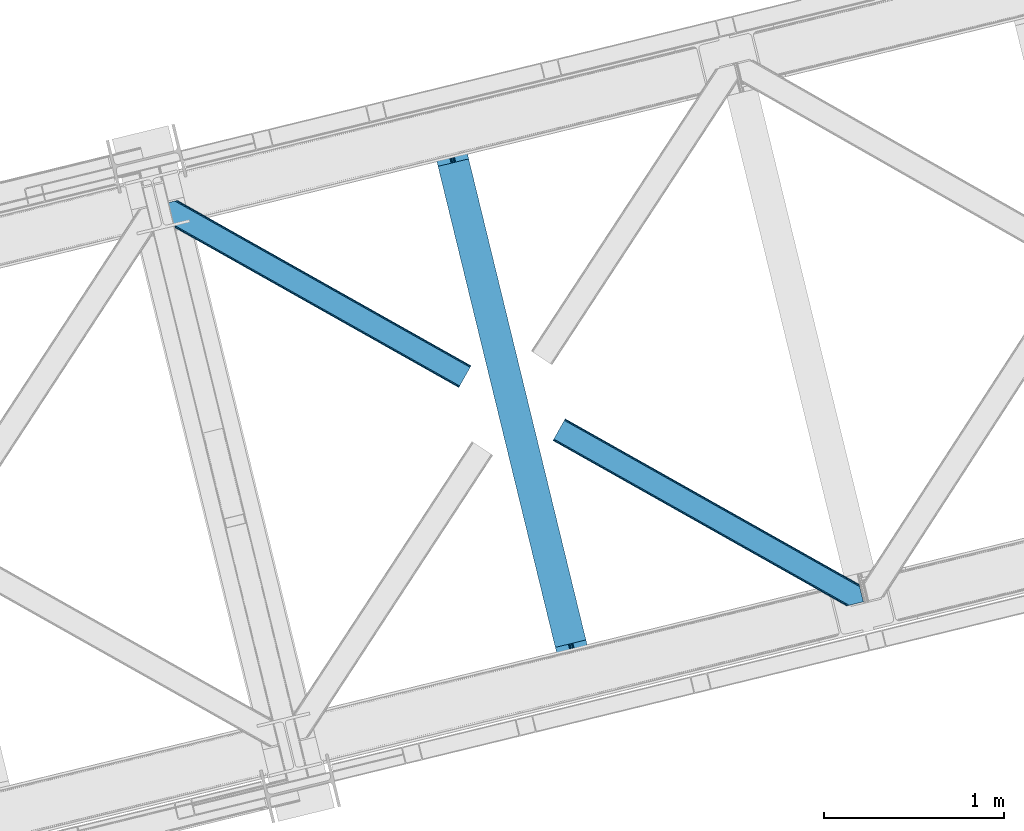
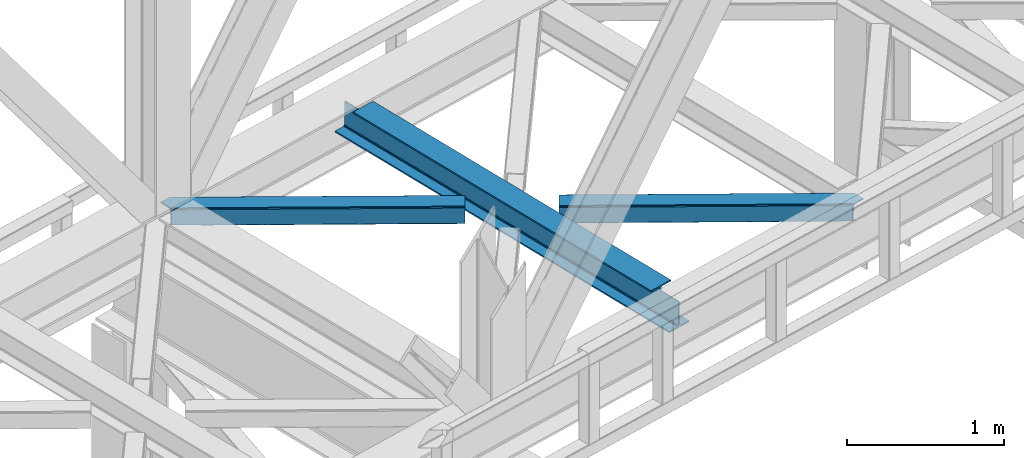
# One storey, part 53 of 92: 2 members, 1 beam.
"""IFC4 building model written with IfcOpenShell, lengths in millimetres."""

from ifc_helpers import new_model, entity, si_unit, converted_unit, derived_unit, direction, frame, origin, place, context, subcontext, project, spatial, triangles, polygons, material, type_object, element, save


model = new_model("IFC4")

# Units and contexts
model_context = context("Model", 3, precision=0.01, world=origin(), true_north=direction((6.12303176911189e-17, 1.0)))
plan_context = context("Plan", 3, precision=0.01, world=origin(), true_north=direction((6.12303176911189e-17, 1.0)))
body_context = subcontext(model_context, "Body", "Model", "MODEL_VIEW")
ifc_project = project(units=[si_unit("LENGTHUNIT", "METRE", prefix="MILLI"), si_unit("AREAUNIT", "SQUARE_METRE"), si_unit("VOLUMEUNIT", "CUBIC_METRE"), converted_unit("PLANEANGLEUNIT", "DEGREE", entity("IfcRatioMeasure", 0.0174532925199433), si_unit("PLANEANGLEUNIT", "RADIAN"), dimensions=[0, 0, 0, 0, 0, 0, 0]), si_unit("MASSUNIT", "GRAM", prefix="KILO"), derived_unit("MASSDENSITYUNIT", [(si_unit("MASSUNIT", "GRAM", prefix="KILO"), 1), (si_unit("LENGTHUNIT", "METRE"), -3)]), derived_unit("MOMENTOFINERTIAUNIT", [(si_unit("LENGTHUNIT", "METRE"), 4)]), si_unit("TIMEUNIT", "SECOND"), si_unit("FREQUENCYUNIT", "HERTZ"), si_unit("THERMODYNAMICTEMPERATUREUNIT", "DEGREE_CELSIUS"), derived_unit("THERMALTRANSMITTANCEUNIT", [(si_unit("MASSUNIT", "GRAM", prefix="KILO"), 1), (si_unit("THERMODYNAMICTEMPERATUREUNIT", "KELVIN"), -1), (si_unit("TIMEUNIT", "SECOND"), -3)]), derived_unit("VOLUMETRICFLOWRATEUNIT", [(si_unit("LENGTHUNIT", "METRE"), 3), (si_unit("TIMEUNIT", "SECOND"), -1)]), derived_unit("MASSFLOWRATEUNIT", [(si_unit("MASSUNIT", "GRAM", prefix="KILO"), 1), (si_unit("TIMEUNIT", "SECOND"), -1)]), derived_unit("ROTATIONALFREQUENCYUNIT", [(si_unit("TIMEUNIT", "SECOND"), -1)]), si_unit("ELECTRICCURRENTUNIT", "AMPERE"), si_unit("ELECTRICVOLTAGEUNIT", "VOLT"), si_unit("POWERUNIT", "WATT"), si_unit("FORCEUNIT", "NEWTON", prefix="KILO"), si_unit("ILLUMINANCEUNIT", "LUX"), si_unit("LUMINOUSFLUXUNIT", "LUMEN"), si_unit("LUMINOUSINTENSITYUNIT", "CANDELA"), derived_unit("USERDEFINED", [(si_unit("MASSUNIT", "GRAM", prefix="KILO"), -1), (si_unit("LENGTHUNIT", "METRE"), -2), (si_unit("TIMEUNIT", "SECOND"), 3), (si_unit("LUMINOUSFLUXUNIT", "LUMEN"), 1)]), derived_unit("LINEARVELOCITYUNIT", [(si_unit("LENGTHUNIT", "METRE"), 1), (si_unit("TIMEUNIT", "SECOND"), -1)]), si_unit("PRESSUREUNIT", "PASCAL"), derived_unit("USERDEFINED", [(si_unit("LENGTHUNIT", "METRE"), -2), (si_unit("MASSUNIT", "GRAM", prefix="KILO"), 1), (si_unit("TIMEUNIT", "SECOND"), -2)]), derived_unit("LINEARFORCEUNIT", [(si_unit("MASSUNIT", "GRAM", prefix="KILO"), 1), (si_unit("LENGTHUNIT", "METRE"), 1), (si_unit("TIMEUNIT", "SECOND"), -2), (si_unit("LENGTHUNIT", "METRE"), -1)]), derived_unit("PLANARFORCEUNIT", [(si_unit("MASSUNIT", "GRAM", prefix="KILO"), 1), (si_unit("LENGTHUNIT", "METRE"), 1), (si_unit("TIMEUNIT", "SECOND"), -2), (si_unit("LENGTHUNIT", "METRE"), -2)])], contexts=[model_context, plan_context])

# Site, building, storey
site_placement = place(None, origin())
site = spatial("IfcSite", under=ifc_project, at=site_placement, CompositionType="ELEMENT")
building_placement = place(site_placement, origin())
building = spatial("IfcBuilding", under=site, at=building_placement, CompositionType="ELEMENT")
storey_placement = place(building_placement, frame((0.0, 0.0, 15900.0)))
storey = spatial("IfcBuildingStorey", under=building, at=storey_placement, Name="05", CompositionType="ELEMENT", Elevation=15900.0)

# Beam
ifc_material = material(Name="Metal painted (White)")
beam_type = type_object("IfcBeamType", PredefinedType="BEAM")
beam_placement = place(storey_placement, frame((-35007.04, 9253.37, 3441.0)))
element("IfcBeam", 1, at=beam_placement, inside=storey, type_object=beam_type, material=ifc_material, ObjectType="Steel Beam", PredefinedType="BEAM", context=body_context, shape_type="Tessellation", body=[
    polygons([(900.98534618944, 41.4445662733092, 11.000000000004), (900.98534618944, 41.444566273307, 2.16573425859679e-12), (170.021610174761, 3040.13999372697, 2.16573425859679e-12), (170.021610174761, 3040.13999372697, 11.000000000004), (834.919806235819, 25.3403919499645, 11.000000000004), (103.956070221148, 3024.03581940362, 11.000000000004), (828.971056214522, 23.8903211957374, 12.2179274798217), (98.007320199847, 3022.5857486494, 12.2179274798217), (823.927949458418, 22.6610105689162, 15.6862915010192), (92.9642134437384, 3021.35643802258, 15.6862915010192), (820.558253255242, 21.8396114687108, 20.8770650821657), (89.5945172405711, 3020.53503892237, 20.8770650821657), (819.374973305552, 21.5511744621195, 27.0000000000047), (88.4112372908766, 3020.24660191578, 27.0000000000047), (81.6103728838888, 3018.58881926485, 27.0000000000047), (81.6103728838888, 3018.58881926485, 203.000000000006), (88.4112372908766, 3020.24660191578, 203.000000000006), (4.33146851719357e-12, 2998.69542745366, 2.16573425859679e-12), (4.33146851719357e-12, 2998.69542745366, 10.9999999999997), (66.0655399536259, 3014.799601777, 11.000000000004), (72.0142899749184, 3016.24967253123, 12.2179274798217), (77.0573967310226, 3017.47898315805, 15.6862915010192), (80.4270929342029, 3018.30038225825, 20.8770650821657), (819.374973305556, 21.5511744621184, 203.000000000006), (812.574108898568, 19.8933918111886, 203.000000000006), (812.574108898564, 19.8933918111886, 27.0000000000047), (811.390828948882, 19.6049548045963, 20.8770650821657), (808.021132745702, 18.7835557043876, 15.6862915010192), (802.978025989598, 17.5542450775675, 12.2179274798217), (797.029275968301, 16.1041743233414, 11.000000000004), (730.963736014684, -1.08286712929839e-12, 10.9999999999997), (730.963736014684, -1.08286712929839e-12, 2.16573425859679e-12), (779.675212882762, 184.415062601691, 203.069791966819), (128.020401343512, 2857.75452019162, 203.000000000006), (128.243282132663, 2856.84017775719, 203.617301946336), (128.256196377186, 2856.7871977843, 217.000003693143), (779.530009633837, 185.01059740407, 217.000003676718), (779.530880241726, 185.00702596319, 204.00000679514), (772.964911718333, 182.385463974442, 203.006342981529), (772.742064056786, 183.299815969775, 203.617301946336), (772.729149812267, 183.352795942668, 217.000003693143), (121.455336555616, 2855.1293963229, 217.000003676718), (121.454465947718, 2855.13296776378, 204.00000679514), (121.310166358673, 2855.72494066435, 203.076120467494), (121.219536936524, 2856.09673754068, 203.000000000006), (780.713494357872, 185.298194377513, 223.122939328039), (784.082490766539, 186.122464201392, 228.313710402595), (789.125126170563, 187.353708426696, 231.78207273546), (795.073705041275, 188.804481281378, 232.999999602236), (861.139155906794, 204.909021065312, 232.999999283132), (861.137682570357, 204.915065042185, 243.999994005812), (691.116301666435, 163.469558245294, 243.999994827032), (691.117775002873, 163.463514268423, 233.000000104353), (757.183225868405, 179.568054052357, 232.999999785253), (763.132130996735, 181.017488520582, 231.782072861012), (768.175695503857, 182.244921343715, 228.313710479427), (771.546082413606, 183.063487001147, 223.12293937232), (120.271851831576, 2854.84179934945, 223.122939328039), (116.902855422901, 2854.01752952557, 228.313710402599), (111.860220018882, 2852.78628530027, 231.782072735464), (105.91164114817, 2851.33551244559, 232.999999602236), (39.8461902826462, 2835.23097266165, 232.999999283128), (39.8476636190837, 2835.22492868478, 243.999994005812), (209.869044523005, 2876.67043548167, 243.999994827032), (209.867571186567, 2876.67647945854, 233.000000104357), (143.802120321044, 2860.57193967461, 232.999999785253), (137.85321519271, 2859.12250520638, 231.782072861007), (132.809650685583, 2857.89507238325, 228.313710479427), (129.439263775843, 2857.07650672582, 223.12293937232)], [[[1, 2, 3, 4]], [[5, 1, 4, 6]], [[7, 5, 6, 8]], [[9, 7, 8, 10]], [[11, 9, 10, 12]], [[13, 11, 12, 14]], [[15, 16, 17, 14, 12, 10, 8, 6, 4, 3, 18, 19, 20, 21, 22, 23]], [[13, 24, 25, 26, 27, 28, 29, 30, 31, 32, 2, 1, 5, 7, 9, 11]], [[2, 32, 18, 3]], [[32, 31, 19, 18]], [[31, 30, 20, 19]], [[27, 26, 15, 23]], [[28, 27, 23, 22]], [[29, 28, 22, 21]], [[30, 29, 21, 20]], [[33, 24, 13, 14, 17, 34, 35, 36, 37, 38]], [[25, 39, 40, 41, 42, 43, 44, 16, 15, 26]], [[39, 25, 24, 33]], [[45, 34, 17, 16]], [[41, 40, 38, 37, 46, 47, 48, 49, 50, 51, 52, 53, 54, 55, 56, 57]], [[42, 58, 59, 60, 61, 62, 63, 64, 65, 66, 67, 68, 69, 36, 35, 43]], [[46, 37, 36, 69]], [[47, 46, 69, 68]], [[48, 47, 68, 67]], [[49, 48, 67, 66]], [[50, 49, 66, 65]], [[51, 50, 65, 64]], [[52, 51, 64, 63]], [[53, 52, 63, 62]], [[54, 53, 62, 61]], [[55, 54, 61, 60]], [[56, 55, 60, 59]], [[57, 56, 59, 58]], [[41, 57, 58, 42]]], closed=False),
])

# Members
member_type_1 = type_object("IfcMemberType", PredefinedType="BRACE")
member_1_placement = place(storey_placement, frame((-36508.39, 10859.65, 3511.0)))
element("IfcMember", 2, at=member_1_placement, inside=storey, type_object=member_type_1, ObjectType="Steel Horizontal Brace", PredefinedType="BRACE", context=body_context, shape_type="Tessellation", body=[
    triangles([(1656.08961181641, 0.0, 122.500662231447), (1656.74538574219, 1.16155700683703, 129.197927856447), (23.8915649414048, 919.172964477539, 122.500662231447), (23.4590332031221, 920.946112060547, 129.197927856447), (1658.60573730469, 4.46600646972729, 134.874325561526), (22.2288757324204, 925.992315673828, 134.874325561526), (1661.39161376953, 9.41337890625073, 138.667117309571), (20.3871276855498, 933.544180297851, 138.667117309571), (1664.6774597168, 15.2490692138672, 139.999594116212), (18.2151672363252, 942.452938842775, 139.999594116212), (1656.08961181641, 0.0, 17.5000946044929), (23.8915649414048, 919.172964477539, 17.5000946044929), (1716.19989624024, 106.738833618165, 139.999594116212), (69.4469238281235, 1034.10780944824, 139.999594116212), (0.0, 1017.17977294922, 139.999594116212), (1719.4857421875, 112.573361206056, 138.667117309571), (78.971923828125, 1036.42976074219, 138.667117309571), (1722.27161865235, 117.520733642579, 134.874325561526), (87.0458496093779, 1038.39824523926, 134.874325561526), (1724.13197021485, 120.826345825195, 129.197927856447), (92.4408691406279, 1039.71328125, 129.197927856447), (1724.78774414062, 121.986740112305, 122.500662231447), (94.3384277343721, 1040.17488098145, 122.500662231447), (1724.78774414062, 121.986740112305, 17.5000946044929), (94.3384277343721, 1040.17488098145, 17.5000946044929), (1656.74538574219, 1.16155700683703, 10.8028289794929), (1658.60573730469, 4.46600646972729, 5.12526855468968), (196.057800292969, 824.821746826172, 8.8831787109375), (196.076403808591, 825.067080688477, 8.50064392089917), (23.3706665039063, 921.307717895508, 10.8691040039084), (195.064837646481, 824.999642944336, 9.50058288574292), (195.734564208986, 824.8798828125, 9.08316650390771), (23.263696289061, 921.748388671875, 9.50058288574292), (195.222967529298, 828.571517944336, 5.12526855468968), (1664.6774597168, 15.2490692138672, 0.0), (1661.39161376953, 9.41337890625073, 1.33247680664135), (193.38121948242, 836.123382568359, 1.33247680664135), (191.209259033203, 845.032141113281, 0.0), (1716.19989624024, 106.738833618165, 0.0), (157.162499999999, 984.711987304689, 0.0), (191.348785400391, 843.224111938476, 9.20757751465135), (191.292974853517, 844.069409179689, 8.85411071777344), (191.104614257813, 845.461184692384, 8.41343994140698), (18.8686157226548, 939.774032592773, 9.50058288574292), (1724.13197021485, 120.826345825195, 10.8028289794929), (92.0548461914077, 1039.61910095215, 10.8702667236357), (150.921020507813, 1006.08858947754, 9.50058288574292), (1722.27161865235, 117.520733642579, 5.12526855468968), (153.148791503903, 1001.17261047363, 5.12526855468968), (152.295355224611, 1004.67704772949, 8.50064392089917), (151.609350585939, 1005.38281860352, 9.00061340332104), (91.582781982419, 1039.50399169922, 9.50058288574292), (1719.4857421875, 112.573361206056, 1.33247680664135), (154.990539550781, 993.62074584961, 1.33247680664135), (156.250927734378, 986.702563476563, 9.11688537597729), (155.811419677731, 987.635064697266, 9.42384338378906), (156.692761230472, 985.761923217773, 8.80760192871094), (157.132269287111, 984.82942199707, 8.50064392089917), (155.316101074219, 988.062945556641, 9.50058288574292), (72.3118652343765, 1034.80660400391, 9.50058288574292), (159.43212890625, 975.399765014648, 6.99957275390625), (188.939630126952, 854.344363403321, 6.99957275390625), (1668.11213378907, 21.3475341796875, 6.99957275390625), (1712.76522216797, 100.639205932617, 6.99957275390625), (19.959246826169, 935.304537963868, 12.1260040283232), (1662.04041137695, 10.5656341552731, 12.1260040283232), (1664.8262878418, 15.5130065917965, 8.3320495605476), (1659.52661132813, 6.0996276855476, 24.4996673583992), (1660.18005981445, 7.26002197265734, 17.8035644531265), (21.6219360351533, 928.485186767579, 24.4996673583992), (21.1894042968779, 930.257171630859, 17.8035644531265), (1716.05106811524, 106.474896240235, 8.3320495605476), (1718.83694458008, 111.422268676759, 12.1260040283232), (77.0906433105483, 1035.9704864502, 12.1260040283232), (1720.69729614258, 114.726718139649, 17.8035644531265), (82.4856628417983, 1037.28552246094, 17.8035644531265), (1721.35074462891, 115.887112426759, 24.4996673583992), (84.3808959960952, 1037.74828491211, 24.4996673583992), (1659.52661132813, 6.0996276855476, 115.501089477541), (21.6219360351533, 928.485186767579, 115.501089477541), (21.1894042968779, 930.257171630859, 122.196029663086), (19.959246826169, 935.304537963868, 127.87475280762), (15.945538330081, 951.765161132813, 133.000021362306), (18.1174987792983, 942.856402587891, 131.667544555665), (0.0, 1017.17977294922, 133.000021362306), (1668.11213378907, 21.3475341796875, 133.000021362306), (1664.8262878418, 15.5130065917965, 131.667544555665), (1662.04041137695, 10.5656341552731, 127.87475280762), (1660.18005981445, 7.26002197265734, 122.196029663086), (1718.83694458008, 111.422268676759, 127.87475280762), (1720.69729614258, 114.726718139649, 122.196029663086), (1721.35074462891, 115.887112426759, 115.501089477541), (1712.76522216797, 100.639205932617, 133.000021362306), (1716.05106811524, 106.474896240235, 131.667544555665), (77.0906433105483, 1035.9704864502, 127.87475280762), (69.0143920898408, 1034.00316467285, 131.667544555665), (82.4856628417983, 1037.28552246094, 122.196029663086), (59.4893920898467, 1031.68121337891, 133.000021362306), (84.3808959960952, 1037.74828491211, 115.501089477541)], [[1, 2, 3], [4, 3, 2], [2, 5, 4], [6, 4, 5], [5, 7, 6], [8, 6, 7], [7, 9, 8], [10, 8, 9], [11, 1, 3], [3, 12, 11], [13, 10, 9], [10, 13, 14], [15, 10, 14], [13, 16, 17], [17, 14, 13], [16, 18, 19], [19, 17, 16], [18, 20, 21], [21, 19, 18], [20, 22, 23], [23, 21, 20], [22, 24, 25], [25, 23, 22], [26, 11, 12], [27, 28, 29], [26, 30, 31], [31, 27, 26], [31, 32, 27], [30, 33, 31], [29, 34, 27], [35, 36, 37], [37, 38, 35], [36, 27, 34], [34, 37, 36], [12, 30, 26], [39, 35, 38], [38, 40, 39], [41, 42, 29], [42, 43, 29], [41, 31, 33], [33, 44, 41], [45, 46, 25], [46, 45, 47], [45, 48, 49], [49, 50, 45], [45, 50, 51], [51, 47, 45], [47, 52, 46], [48, 53, 54], [54, 49, 48], [53, 39, 40], [40, 54, 53], [25, 24, 45], [51, 55, 56], [50, 57, 55], [50, 58, 57], [47, 59, 52], [60, 52, 59], [61, 40, 62], [54, 58, 49], [58, 54, 40], [49, 58, 50], [40, 61, 58], [62, 40, 38], [37, 43, 38], [43, 37, 34], [38, 43, 62], [34, 29, 43], [63, 64, 62], [61, 62, 64], [63, 62, 43], [41, 65, 66], [41, 44, 65], [43, 66, 67], [66, 43, 42], [42, 41, 66], [43, 67, 63], [68, 69, 70], [71, 70, 69], [69, 66, 71], [65, 71, 66], [72, 58, 61], [57, 72, 55], [57, 58, 72], [56, 55, 72], [73, 74, 59], [59, 72, 73], [74, 60, 59], [73, 75, 76], [76, 74, 73], [75, 77, 78], [78, 76, 75], [61, 64, 72], [79, 68, 80], [70, 80, 68], [81, 6, 82], [80, 70, 3], [4, 81, 3], [81, 4, 6], [81, 80, 3], [70, 12, 3], [71, 65, 33], [33, 30, 71], [30, 12, 71], [70, 71, 12], [83, 10, 15], [10, 84, 8], [84, 10, 83], [15, 85, 83], [84, 82, 8], [44, 33, 65], [8, 82, 6], [86, 87, 84], [84, 83, 86], [87, 88, 82], [82, 84, 87], [88, 89, 81], [81, 82, 88], [89, 79, 80], [80, 81, 89], [20, 90, 91], [92, 24, 22], [20, 91, 22], [20, 18, 90], [91, 92, 22], [90, 18, 16], [93, 13, 9], [13, 94, 16], [94, 13, 93], [94, 90, 16], [45, 73, 48], [77, 24, 92], [24, 75, 45], [75, 24, 77], [45, 75, 73], [39, 64, 35], [53, 48, 73], [73, 72, 53], [72, 64, 39], [39, 53, 72], [88, 7, 5], [9, 86, 93], [9, 87, 86], [87, 9, 7], [88, 87, 7], [79, 1, 11], [2, 89, 88], [5, 2, 88], [89, 2, 1], [79, 89, 1], [36, 66, 27], [35, 64, 63], [63, 67, 35], [67, 66, 36], [36, 35, 67], [26, 27, 66], [11, 68, 79], [69, 11, 26], [11, 69, 68], [69, 26, 66], [95, 96, 17], [19, 95, 17], [19, 21, 97], [95, 19, 97], [97, 21, 23], [96, 14, 17], [15, 98, 85], [15, 14, 98], [96, 98, 14], [97, 23, 99], [78, 25, 76], [23, 78, 99], [25, 46, 76], [23, 25, 78], [52, 76, 46], [74, 76, 52], [60, 74, 52], [93, 83, 98], [93, 86, 83], [83, 85, 98], [77, 92, 78], [99, 78, 92], [92, 91, 99], [97, 99, 91], [91, 90, 97], [95, 97, 90], [90, 94, 95], [96, 95, 94], [94, 93, 96], [98, 96, 93]]),
])
member_type_2 = type_object("IfcMemberType", PredefinedType="BRACE")
member_2_placement = place(storey_placement, frame((-34329.5, 9647.05, 3511.0)))
element("IfcMember", 3, at=member_2_placement, inside=storey, type_object=member_type_2, ObjectType="Steel Horizontal Brace", PredefinedType="BRACE", context=body_context, shape_type="Tessellation", body=[
    triangles([(1645.8158203125, 3.74570159912037, 138.667117309571), (1655.3408203125, 6.06765289306531, 139.999594116212), (8.58552246094041, 933.435466003417, 139.999594116212), (5.29967651367042, 927.600938415528, 138.667117309571), (1637.7395690918, 1.77663574218786, 134.874325561526), (2.51380004882958, 922.653565979004, 134.874325561526), (1632.34454956055, 0.461599731444949, 129.197927856447), (0.65344848632958, 919.347953796387, 129.197927856447), (1630.4516418457, 0.0, 122.500662231447), (0.0, 918.187559509277, 122.500662231447), (1630.4516418457, 0.0, 17.5000946044929), (0.0, 918.187559509277, 17.5000946044929), (1706.5725769043, 97.7219421386708, 139.999594116212), (1724.78774414062, 22.9956893920898, 139.999594116212), (60.1102844238267, 1024.92639312744, 139.999594116212), (1701.3287109375, 119.229350280761, 129.197927856447), (1700.89617919922, 121.001335144043, 122.500662231447), (68.0446838378921, 1039.01390533447, 129.197927856447), (68.6958068847671, 1040.17429962158, 122.500662231447), (1702.5588684082, 114.183146667479, 134.874325561526), (66.1820068359375, 1035.70829315185, 134.874325561526), (1704.40061645508, 106.63011932373, 138.667117309571), (63.3961303710967, 1030.76092071533, 138.667117309571), (1700.89617919922, 121.001335144043, 17.5000946044929), (68.6958068847671, 1040.17429962158, 17.5000946044929), (0.65344848632958, 919.347953796387, 10.8028289794929), (1633.02822875977, 0.628450012207395, 10.9377044677749), (2.51380004882958, 922.653565979004, 5.12526855468968), (5.29967651367042, 927.600938415528, 1.33247680664135), (1569.79720458984, 46.5547164916989, 1.33247680664135), (1573.68999023438, 34.8100845336903, 8.52041015625218), (1571.51337890625, 39.517936706543, 5.59500732422021), (1572.28775024414, 36.3402236938473, 7.52047119140843), (1573.35047607422, 35.1809921264648, 8.278564453125), (1572.99003295898, 35.5751541137688, 8.02044067383031), (1572.6272644043, 35.9693161010746, 7.76231689453198), (1633.97700805664, 0.859831237792605, 8.52041015625218), (1567.62756958008, 55.4634750366204, 0.0), (8.58552246094041, 933.435466003417, 0.0), (1533.57848510742, 195.142158508301, 0.0), (60.1102844238267, 1024.92639312744, 0.0), (1566.72994995117, 59.1411575317379, 7.52047119140843), (1567.24852294922, 57.3430114746097, 7.90300598144677), (1567.78569946289, 56.436090087891, 8.1076446533225), (1568.32520141602, 55.5198669433594, 8.31460876464917), (1568.41124267578, 55.3762710571282, 8.3471649169951), (1568.86237792969, 54.6129455566406, 8.52041015625218), (1655.15013427734, 6.02056274414099, 8.52041015625218), (5.95079956054542, 928.75319366455, 12.1260040283232), (1647.69710083008, 4.20381317138708, 12.1260040283232), (8.73435058593896, 933.699403381348, 8.3320495605476), (12.0225219726563, 939.535093688964, 6.99957275390625), (1565.35794067383, 64.7751159667969, 6.99957275390625), (1642.29975585937, 2.88877716064417, 17.8035644531265), (4.08812255859084, 925.447581481933, 17.8035644531265), (1640.40452270508, 2.42659606933557, 24.4996673583992), (3.43467407226854, 924.287187194825, 24.4996673583992), (1640.40452270508, 2.42659606933557, 115.501089477541), (3.43467407226854, 924.287187194825, 115.501089477541), (1647.69710083008, 4.20381317138708, 127.87475280762), (1655.77102661133, 6.17229766845594, 131.667544555665), (1642.29975585937, 2.88877716064417, 122.196029663086), (1665.29602661133, 8.49366760253906, 133.000021362306), (1724.78774414062, 22.9956893920898, 133.000021362306), (4.08812255859084, 925.447581481933, 122.196029663086), (5.95079956054542, 928.75319366455, 127.87475280762), (8.73435058593896, 933.699403381348, 131.667544555665), (12.0225219726563, 939.535093688964, 133.000021362306), (1708.84220581055, 88.4097198486324, 133.000021362306), (56.6732849121108, 1018.82676544189, 133.000021362306), (1535.84811401367, 185.831098937988, 6.99957275390625), (56.6732849121108, 1018.82676544189, 6.99957275390625), (68.0446838378921, 1039.01390533447, 10.8028289794929), (62.747332763669, 1029.60866546631, 12.1260040283232), (64.6100097656235, 1032.91427764893, 17.8035644531265), (65.2611328124985, 1034.07467193603, 24.4996673583992), (66.1820068359375, 1035.70829315185, 5.12526855468968), (63.3961303710967, 1030.76092071533, 1.33247680664135), (59.9614562988281, 1024.66245574951, 8.3320495605476), (62.747332763669, 1029.60866546631, 127.87475280762), (65.2611328124985, 1034.07467193603, 115.501089477541), (64.6100097656235, 1032.91427764893, 122.196029663086), (59.9614562988281, 1024.66245574951, 131.667544555665), (1703.16813354492, 111.689112854003, 24.4996673583992), (1703.16813354492, 111.689112854003, 115.501089477541), (1706.67024536133, 97.318478393554, 131.667544555665), (1704.82849731445, 104.870924377441, 127.87475280762), (1703.59833984375, 109.917127990722, 122.196029663086), (1704.82849731445, 104.870924377441, 12.1260040283232), (1706.52839355469, 97.9004196166989, 8.52041015625218), (1701.70078125, 117.702699279786, 8.52041015625218), (1703.59833984375, 109.917127990722, 17.8035644531265), (1701.48451538086, 118.591017150879, 10.9365417480476), (1534.47610473633, 191.464476013183, 7.52047119140843), (1529.69267578125, 211.087696838378, 5.59500732422021), (1528.9159790039, 214.266572570801, 7.52047119140843), (1531.4065246582, 204.050917053222, 1.33247680664135), (1529.11596679688, 214.688639831542, 8.22740478515698), (1529.01597290039, 214.477024841308, 7.87393798828271), (1529.89963989258, 214.452607727051, 8.52041015625218), (1534.35053100586, 192.705097961425, 7.85649719238427), (1534.72725219726, 194.649165344237, 8.52041015625218)], [[1, 2, 3], [3, 4, 1], [5, 1, 4], [4, 6, 5], [7, 5, 6], [6, 8, 7], [9, 7, 8], [8, 10, 9], [11, 9, 12], [10, 12, 9], [2, 13, 3], [2, 14, 13], [15, 3, 13], [16, 17, 18], [19, 18, 17], [20, 16, 21], [18, 21, 16], [22, 20, 23], [21, 23, 20], [13, 22, 15], [23, 15, 22], [17, 24, 19], [25, 19, 24], [26, 27, 11], [28, 29, 30], [27, 26, 31], [26, 28, 32], [32, 33, 26], [34, 26, 35], [34, 31, 26], [26, 36, 35], [26, 33, 36], [31, 37, 27], [30, 32, 28], [38, 30, 29], [29, 39, 38], [11, 12, 26], [40, 38, 39], [39, 41, 40], [33, 42, 43], [36, 43, 44], [35, 44, 45], [34, 46, 47], [34, 45, 46], [47, 31, 34], [45, 34, 35], [44, 35, 36], [43, 36, 33], [48, 37, 47], [31, 47, 37], [49, 50, 47], [47, 51, 49], [47, 46, 51], [50, 48, 47], [52, 43, 42], [51, 46, 45], [45, 52, 51], [45, 44, 52], [43, 52, 44], [42, 53, 52], [54, 50, 49], [49, 55, 54], [56, 54, 55], [55, 57, 56], [58, 56, 59], [57, 59, 56], [60, 61, 1], [5, 60, 1], [5, 7, 62], [60, 5, 62], [62, 7, 9], [61, 2, 1], [14, 63, 64], [14, 2, 63], [61, 63, 2], [62, 9, 58], [56, 11, 54], [9, 56, 58], [11, 27, 54], [9, 11, 56], [37, 54, 27], [50, 54, 37], [48, 50, 37], [62, 58, 65], [59, 65, 58], [60, 62, 66], [65, 66, 62], [61, 60, 67], [66, 67, 60], [63, 61, 68], [67, 68, 61], [69, 63, 68], [63, 69, 64], [68, 70, 69], [53, 71, 52], [72, 52, 71], [73, 74, 75], [76, 19, 25], [73, 75, 25], [73, 77, 74], [75, 76, 25], [74, 77, 78], [72, 41, 39], [41, 79, 78], [79, 41, 72], [79, 74, 78], [18, 80, 21], [81, 19, 76], [19, 82, 18], [82, 19, 81], [18, 82, 80], [15, 70, 3], [23, 21, 80], [80, 83, 23], [83, 70, 15], [15, 23, 83], [49, 29, 28], [39, 52, 72], [39, 51, 52], [51, 39, 29], [49, 51, 29], [57, 12, 10], [26, 55, 49], [28, 26, 49], [55, 26, 12], [57, 55, 12], [4, 66, 6], [3, 70, 68], [68, 67, 3], [67, 66, 4], [4, 3, 67], [8, 6, 66], [10, 59, 57], [65, 10, 8], [10, 65, 59], [65, 8, 66], [84, 85, 76], [81, 76, 85], [86, 69, 70], [70, 83, 86], [87, 86, 83], [83, 80, 87], [88, 87, 80], [80, 82, 88], [85, 88, 82], [82, 81, 85], [87, 20, 22], [89, 90, 91], [20, 87, 88], [86, 87, 22], [86, 13, 69], [14, 69, 13], [69, 14, 64], [86, 22, 13], [24, 17, 84], [91, 92, 89], [92, 24, 84], [93, 92, 91], [93, 24, 92], [17, 85, 84], [88, 16, 20], [17, 16, 88], [85, 17, 88], [40, 71, 53], [94, 95, 96], [40, 94, 71], [94, 97, 95], [94, 40, 97], [38, 40, 53], [42, 38, 53], [32, 42, 33], [42, 30, 38], [42, 32, 30], [73, 25, 24], [98, 99, 77], [96, 77, 99], [96, 95, 77], [73, 93, 100], [100, 77, 73], [100, 98, 77], [93, 91, 100], [78, 77, 95], [97, 40, 41], [41, 78, 97], [95, 97, 78], [24, 93, 73], [72, 71, 94], [94, 79, 72], [101, 102, 79], [79, 94, 101], [74, 79, 102], [90, 89, 102], [74, 102, 89], [92, 84, 75], [76, 75, 84], [89, 92, 74], [75, 74, 92], [101, 94, 99], [102, 101, 99], [91, 90, 102], [102, 100, 91]]),
])

save(model, "model.ifc")
